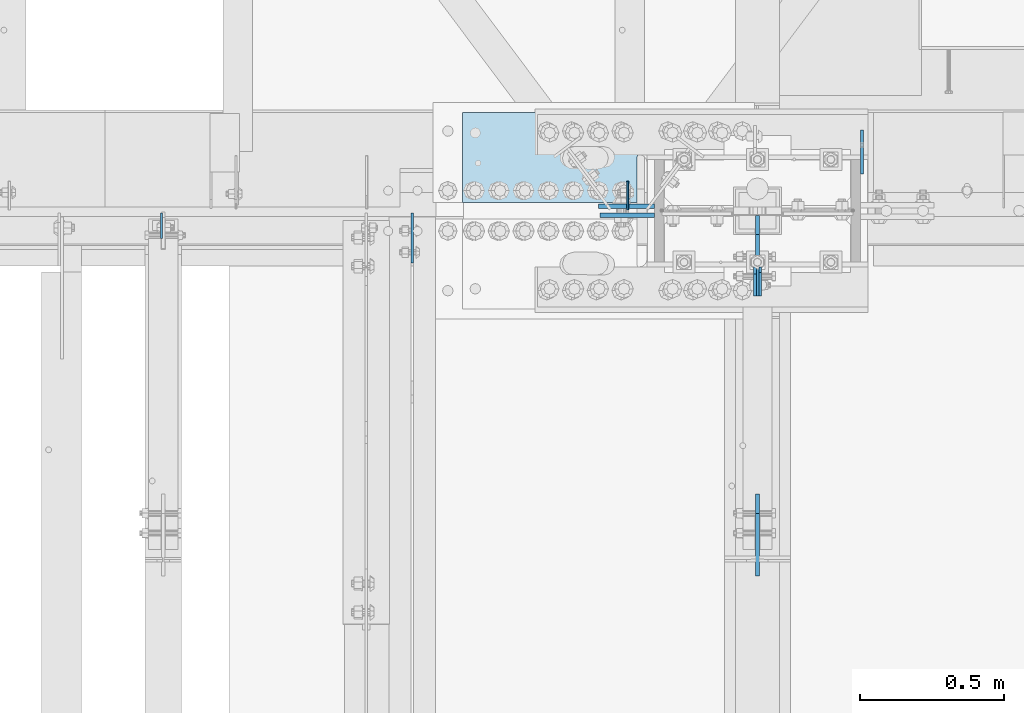
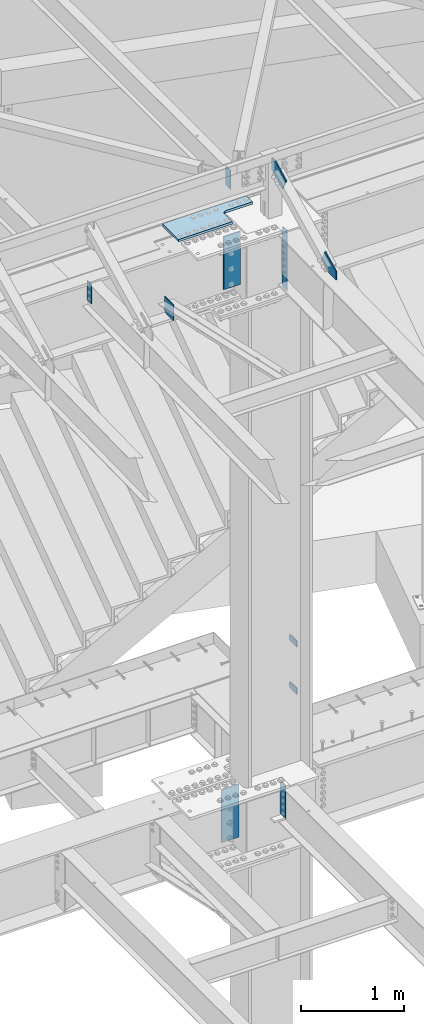
# One storey, part 1639 of 1763: 12 plates, 6 elements without a shape of their own.
"""IFC2X3 building model written with IfcOpenShell, lengths in millimetres."""

from ifc_helpers import new_model, si_unit, frame, origin_with_axes, place, context, subcontext, project, spatial, faceted_brep, material, type_object, element, aggregate, save


model = new_model("IFC2X3")

# Units and contexts
model_context = context("Model", 3, precision=1e-05, world=origin_with_axes())
body_context = subcontext(model_context, "Body", "Model", "MODEL_VIEW")
ifc_project = project(units=[si_unit("LENGTHUNIT", "METRE", prefix="MILLI"), si_unit("AREAUNIT", "SQUARE_METRE"), si_unit("VOLUMEUNIT", "CUBIC_METRE"), si_unit("MASSUNIT", "GRAM", prefix="KILO"), si_unit("TIMEUNIT", "SECOND"), si_unit("PLANEANGLEUNIT", "RADIAN"), si_unit("SOLIDANGLEUNIT", "STERADIAN"), si_unit("THERMODYNAMICTEMPERATUREUNIT", "DEGREE_CELSIUS"), si_unit("LUMINOUSINTENSITYUNIT", "LUMEN")], contexts=[model_context])

# Site, building, storey
site_placement = place(None, origin_with_axes())
site = spatial("IfcSite", under=ifc_project, at=site_placement, CompositionType="ELEMENT")
building_placement = place(site_placement, origin_with_axes())
building = spatial("IfcBuilding", under=site, at=building_placement, Name="Undefined", CompositionType="ELEMENT")
storey_placement = place(building_placement, origin_with_axes())
storey = spatial("IfcBuildingStorey", under=building, at=storey_placement, Name="Undefined", CompositionType="ELEMENT", Elevation=0.0)

# Assembly, plates
assembly_1_placement = place(storey_placement, origin_with_axes())
assembly_1 = element("IfcElementAssembly", 1, at=assembly_1_placement, inside=storey, Name="COLUMN", AssemblyPlace="NOTDEFINED", PredefinedType="RIGID_FRAME")
ifc_material_1 = material(Name="STEEL/A36")
plate_type_1 = type_object("IfcPlateType", PredefinedType="NOTDEFINED")
plate_1_placement = place(assembly_1_placement, frame((-34587.8872736983, 52247.8, 6489.69999847412), z_axis=(0.0, 0.0, -1.0), x_axis=(0.0, 1.0, 0.0)))
plate_1 = element("IfcPlate", 2, at=plate_1_placement, type_object=plate_type_1, material=ifc_material_1, Name="PLATE", context=body_context, shape_type="Brep", body=[
    faceted_brep([(0.0, -4.76249999999982, 0.0), (0.0, -4.76250000000073, 76.1999969482422), (0.0, 4.76250000000073, 76.1999969482422), (0.0, 4.76249999999982, 0.0), (114.299995422363, -4.76250000000073, 76.1999969482422), (114.299995422363, 4.76250000000073, 76.1999969482422), (126.073542436527, -4.76250000000073, 74.3352502937696), (126.073542436527, 4.76250000000073, 74.3352502937696), (136.694612637817, -4.76250000000073, 68.923544725345), (136.694612637817, 4.76250000000073, 68.923544725345), (145.123541673587, -4.76250000000073, 60.4946156895749), (145.123541673587, 4.76250000000073, 60.4946156895749), (150.535247242013, -4.76250000000073, 49.8735454882844), (150.535247242013, 4.76250000000073, 49.8735454882844), (152.399993896484, -4.76250000000073, 38.0999984741211), (152.399993896484, 4.76250000000073, 38.0999984741211), (150.535247242013, -4.76250000000073, 26.3264514599578), (150.535247242013, 4.76250000000073, 26.3264514599578), (145.123541673587, -4.76250000000073, 15.7053812586673), (145.123541673587, 4.76250000000073, 15.7053812586673), (136.694612637817, -4.76250000000073, 7.27645222289721), (136.694612637817, 4.76250000000073, 7.27645222289721), (126.073542436527, -4.76250000000073, 1.86474665447258), (126.073542436527, 4.76250000000073, 1.86474665447258), (114.299995422363, -4.76250000000073, 0.0), (114.299995422363, 4.76250000000073, 0.0)], [[[0, 1, 2, 3]], [[1, 4, 5, 2]], [[4, 6, 7, 5]], [[6, 8, 9, 7]], [[8, 10, 11, 9]], [[10, 12, 13, 11]], [[12, 14, 15, 13]], [[14, 16, 17, 15]], [[16, 18, 19, 17]], [[18, 20, 21, 19]], [[20, 22, 23, 21]], [[22, 24, 25, 23]], [[24, 0, 3, 25]], [[5, 7, 9, 11, 13, 15, 17, 19, 21, 23, 25, 3, 2]], [[24, 22, 20, 18, 16, 14, 12, 10, 8, 6, 4, 1, 0]]]),
])
plate_2_placement = place(assembly_1_placement, frame((-34587.8872736983, 52247.8, 5930.89999847412), z_axis=(0.0, 0.0, -1.0), x_axis=(0.0, 1.0, 0.0)))
plate_2 = element("IfcPlate", 3, at=plate_2_placement, type_object=plate_type_1, material=ifc_material_1, Name="PLATE", context=body_context, shape_type="Brep", body=[
    faceted_brep([(0.0, -4.76249999999982, 0.0), (0.0, -4.76250000000073, 76.1999969482422), (0.0, 4.76250000000073, 76.1999969482422), (0.0, 4.76249999999982, 0.0), (114.299995422363, -4.76250000000073, 76.1999969482422), (114.299995422363, 4.76250000000073, 76.1999969482422), (126.073542436527, -4.76250000000073, 74.3352502937696), (126.073542436527, 4.76250000000073, 74.3352502937696), (136.694612637817, -4.76250000000073, 68.923544725345), (136.694612637817, 4.76250000000073, 68.923544725345), (145.123541673587, -4.76250000000073, 60.4946156895749), (145.123541673587, 4.76250000000073, 60.4946156895749), (150.535247242013, -4.76250000000073, 49.8735454882844), (150.535247242013, 4.76250000000073, 49.8735454882844), (152.399993896484, -4.76250000000073, 38.0999984741211), (152.399993896484, 4.76250000000073, 38.0999984741211), (150.535247242013, -4.76250000000073, 26.3264514599578), (150.535247242013, 4.76250000000073, 26.3264514599578), (145.123541673587, -4.76250000000073, 15.7053812586673), (145.123541673587, 4.76250000000073, 15.7053812586673), (136.694612637817, -4.76250000000073, 7.27645222289721), (136.694612637817, 4.76250000000073, 7.27645222289721), (126.073542436527, -4.76250000000073, 1.86474665447258), (126.073542436527, 4.76250000000073, 1.86474665447258), (114.299995422363, -4.76250000000073, 0.0), (114.299995422363, 4.76250000000073, 0.0)], [[[0, 1, 2, 3]], [[1, 4, 5, 2]], [[4, 6, 7, 5]], [[6, 8, 9, 7]], [[8, 10, 11, 9]], [[10, 12, 13, 11]], [[12, 14, 15, 13]], [[14, 16, 17, 15]], [[16, 18, 19, 17]], [[18, 20, 21, 19]], [[20, 22, 23, 21]], [[22, 24, 25, 23]], [[24, 0, 3, 25]], [[5, 7, 9, 11, 13, 15, 17, 19, 21, 23, 25, 3, 2]], [[24, 22, 20, 18, 16, 14, 12, 10, 8, 6, 4, 1, 0]]]),
])
plate_type_2 = type_object("IfcPlateType", PredefinedType="NOTDEFINED")
plate_3_placement = place(assembly_1_placement, frame((-34940.3122734657, 51927.1249999994, 11716.7628223783), z_axis=(0.0, -1.0, 0.0), x_axis=(0.0, 0.0, -1.0)))
plate_3 = element("IfcPlate", 4, at=plate_3_placement, type_object=plate_type_2, material=ifc_material_1, Name="PLATE", context=body_context, shape_type="Brep", body=[
    faceted_brep([(0.0, -3.96899999999732, 19.0499992370605), (-1.18234311230481e-11, -3.96900000000096, 101.599998474121), (-1.18234311230481e-11, 3.96900000000096, 101.599998474121), (0.0, 3.96899999999732, 19.0499992370605), (717.549987792969, -3.96899999999732, 101.599998474121), (717.549987792969, 3.96899999999732, 101.599998474121), (717.549987792969, -3.96899999999732, 19.0499992370605), (717.549987792969, 3.96899999999732, 19.0499992370605), (698.499988555908, -3.96899999999732, 0.0), (698.499988555908, 3.96899999999732, 0.0), (19.0499992370605, -3.96899999999732, 0.0), (19.0499992370605, 3.96899999999732, 0.0)], [[[0, 1, 2, 3]], [[1, 4, 5, 2]], [[4, 6, 7, 5]], [[6, 8, 9, 7]], [[8, 10, 11, 9]], [[10, 0, 3, 11]], [[5, 7, 9, 11, 3, 2]], [[10, 8, 6, 4, 1, 0]]]),
])

# Assembly, plate
assembly_2_placement = place(storey_placement, origin_with_axes())
assembly_2 = element("IfcElementAssembly", 5, at=assembly_2_placement, inside=storey, Name="BEAM", AssemblyPlace="NOTDEFINED", PredefinedType="RIGID_FRAME")
plate_type_3 = type_object("IfcPlateType", PredefinedType="NOTDEFINED")
plate_4_placement = place(assembly_2_placement, frame((-34949.8372736984, 50858.8044431339, 11721.3897393301), z_axis=(0.0, -0.0206852279954837, 0.999786037781472), x_axis=(0.0, 0.999786037781472, 0.0206852279954825)))
plate_4 = element("IfcPlate", 6, at=plate_4_placement, type_object=plate_type_3, material=ifc_material_1, Name="PLATE", context=body_context, shape_type="Brep", body=[
    faceted_brep([(0.0, -6.34999999999491, 1.45519152283669e-11), (1.45519152283669e-11, -6.34999999999854, 101.599998474047), (1.45519152283669e-11, 6.34999999999854, 101.599998474047), (0.0, 6.34999999999491, -2.91038304567337e-11), (218.951583862981, -6.34999999999854, 205.463943481234), (218.951583862981, 6.34999999999854, 205.463943481234), (284.27273559654, -6.34999999999854, 67.7725906370797), (284.27273559654, 6.34999999999854, 67.7725906370797), (141.413955688891, -6.34999999999854, -4.72937244921923e-11), (141.413955688891, 6.34999999999854, -4.72937244921923e-11)], [[[0, 1, 2, 3]], [[1, 4, 5, 2]], [[4, 6, 7, 5]], [[6, 8, 9, 7]], [[8, 0, 3, 9]], [[5, 7, 9, 3, 2]], [[8, 6, 4, 1, 0]]]),
])
aggregate(assembly_2, [plate_4])

assembly_3_placement = place(storey_placement, origin_with_axes())
assembly_3 = element("IfcElementAssembly", 7, at=assembly_3_placement, inside=storey, Name="COLUMN", AssemblyPlace="NOTDEFINED", PredefinedType="RIGID_FRAME")
plate_type_4 = type_object("IfcPlateType", PredefinedType="NOTDEFINED")
plate_5_placement = place(assembly_3_placement, frame((-34949.8372736984, 52104.9250000007, 12416.9092242053), z_axis=(0.0, -1.0, 0.0), x_axis=(0.0, 0.0, -1.0)))
plate_5 = element("IfcPlate", 8, at=plate_5_placement, type_object=plate_type_4, material=ifc_material_1, Name="PLATE", context=body_context, shape_type="Brep", body=[
    faceted_brep([(0.0, -6.34999999999491, 1.45519152283669e-11), (0.0, -6.34999999999854, 66.6750030517578), (0.0, 6.34999999999854, 66.6750030517578), (0.0, 6.34999999999491, -2.91038304567337e-11), (109.25341796875, -6.34999999999854, 278.831817626953), (109.25341796875, 6.34999999999854, 278.831817626953), (245.564117431641, -6.34999999999854, 210.676483154297), (245.564117431641, 6.34999999999854, 210.676483154297), (140.225875854492, -6.34999999999854, 0.0), (140.225875854492, 6.34999999999854, 0.0)], [[[0, 1, 2, 3]], [[1, 4, 5, 2]], [[4, 6, 7, 5]], [[6, 8, 9, 7]], [[8, 0, 3, 9]], [[5, 7, 9, 3, 2]], [[8, 6, 4, 1, 0]]]),
])
aggregate(assembly_3, [plate_5])

# Plate
ifc_material_2 = material(Name="STEEL/A572-GR.50")
plate_type_5 = type_object("IfcPlateType", PredefinedType="NOTDEFINED")
plate_6_placement = place(assembly_1_placement, frame((-34958.5685236983, 51927.125, 5165.725), z_axis=(0.0, -1.0, 0.0), x_axis=(0.0, 0.0, -1.0)))
plate_6 = element("IfcPlate", 9, at=plate_6_placement, type_object=plate_type_5, material=ifc_material_2, Name="PLATE", context=body_context, shape_type="Brep", body=[
    faceted_brep([(25.3999996185303, -4.76250000000073, 0.0), (0.0, -4.76250000000073, 25.3999996185303), (0.0, 4.76250000000073, 25.3999996185303), (25.3999996185303, 4.76250000000073, 0.0), (1.45519152283669e-11, -4.76250000000448, 101.60001373291), (390.524993896484, -4.76249999999709, 101.599998474121), (390.524993896484, 4.76249999999709, 101.599998474121), (0.0, 4.76250000000243, 101.60001373291), (390.524993896484, -4.76249999999709, 0.0), (390.524993896484, 4.76249999999709, 0.0)], [[[0, 1, 2, 3]], [[4, 5, 6, 7]], [[5, 8, 9, 6]], [[9, 8, 0, 3]], [[7, 6, 9, 3, 2]], [[4, 7, 2, 1]], [[8, 5, 4, 1, 0]]]),
])

# Assembly, plate
assembly_4_placement = place(storey_placement, origin_with_axes())
assembly_4 = element("IfcElementAssembly", 10, at=assembly_4_placement, inside=storey, Name="BEAM", AssemblyPlace="NOTDEFINED", PredefinedType="RIGID_FRAME")
plate_type_6 = type_object("IfcPlateType", PredefinedType="NOTDEFINED")
plate_7_placement = place(assembly_4_placement, frame((-35398.7396174484, 52123.9749997282, 12407.9), z_axis=(0.0, 1.0, 0.0), x_axis=(0.0, 0.0, -1.0)))
plate_7 = element("IfcPlate", 11, at=plate_7_placement, type_object=plate_type_6, material=ifc_material_1, Name="PLATE", context=body_context, shape_type="Brep", body=[
    faceted_brep([(1.81898940354586e-12, -3.17500000000291, 0.0), (-2.52839527092874e-10, -3.17500000000001, 98.4250000002357), (4.17785486206412e-08, 3.17500000000001, 98.425000000243), (-1.81898940354586e-12, 3.17499999997381, 0.0), (228.600006103516, -3.17499999999927, 98.4250030517578), (228.600006103516, 3.17499999999927, 98.4250030517578), (228.600006103516, -3.17500000001019, -7.27595761418343e-12), (228.600006103516, 3.17499999999563, -7.27595761418343e-12)], [[[0, 1, 2, 3]], [[1, 4, 5, 2]], [[4, 6, 7, 5]], [[6, 0, 3, 7]], [[5, 7, 3, 2]], [[6, 4, 1, 0]]]),
])
aggregate(assembly_4, [plate_7])

# Plate
ifc_material_3 = material(Name="STEEL/A572-50")
plate_type_7 = type_object("IfcPlateType", PredefinedType="NOTDEFINED")
plate_8_placement = place(assembly_1_placement, frame((-35494.3497736984, 52104.9250002128, 11045.8249917654), z_axis=(1.0, 0.0, 0.0), x_axis=(0.0, 0.0, 1.0)))
plate_8 = element("IfcPlate", 12, at=plate_8_placement, type_object=plate_type_7, material=ifc_material_3, Name="SHEAR TAB", context=body_context, shape_type="Brep", body=[
    faceted_brep([(-7.27595761418343e-12, -7.9375, 0.0), (0.0, -7.9375, 187.324996948242), (0.0, 7.9375, 187.324996948242), (-7.27595761418343e-12, 7.9375, 0.0), (625.474975585938, -7.9375, 187.324996948242), (625.474975585938, 7.9375, 187.324996948242), (625.474975585938, -7.9375, 0.0), (625.474975585938, 7.9375, 0.0)], [[[0, 1, 2, 3]], [[1, 4, 5, 2]], [[4, 6, 7, 5]], [[6, 0, 3, 7]], [[5, 7, 3, 2]], [[6, 4, 1, 0]]]),
])

# Assembly, plate
assembly_5_placement = place(storey_placement, origin_with_axes())
assembly_5 = element("IfcElementAssembly", 13, at=assembly_5_placement, inside=storey, Name="TOP PLATE", AssemblyPlace="NOTDEFINED", PredefinedType="RIGID_FRAME")
plate_type_8 = type_object("IfcPlateType", PredefinedType="NOTDEFINED")
plate_9_placement = place(assembly_5_placement, frame((-35970.5997736984, 52149.3750002128, 11761.7874917654), z_axis=(0.0, 1.0, 0.0), x_axis=(1.0, 0.0, 0.0)))
plate_9 = element("IfcPlate", 14, at=plate_9_placement, type_object=plate_type_8, material=ifc_material_3, Name="TOP PLATE", context=body_context, shape_type="Brep", body=[
    faceted_brep([(0.0, -14.2875000000058, 0.0), (0.0, -14.2875000000004, 311.149993896484), (0.0, 14.2875000000004, 311.149993896484), (0.0, 14.2875000000058, 0.0), (939.799987792969, -14.2875000000004, 311.149993896484), (939.799987792969, 14.2875000000004, 311.149993896484), (939.799987792969, -14.2875000000004, 193.675003051758), (939.799987792969, 14.2875000000004, 193.675003051758), (644.525001525879, -14.2875000000004, 193.675003051758), (644.525001525879, 14.2875000000004, 193.675003051758), (628.729742271084, -14.2875000000004, 190.533130640011), (628.729742271084, 14.2875000000004, 190.533130640011), (615.339168053448, -14.2875000000004, 181.58583499831), (615.339168053448, 14.2875000000004, 181.58583499831), (606.391872411747, -14.2875000000004, 168.195260780674), (606.391872411747, 14.2875000000004, 168.195260780674), (603.25, -14.2875000000004, 152.400001525879), (603.25, 14.2875000000004, 152.400001525879), (603.25, -14.2875000000004, 0.0), (603.25, 14.2875000000004, 0.0)], [[[0, 1, 2, 3]], [[1, 4, 5, 2]], [[4, 6, 7, 5]], [[6, 8, 9, 7]], [[8, 10, 11, 9]], [[10, 12, 13, 11]], [[12, 14, 15, 13]], [[14, 16, 17, 15]], [[16, 18, 19, 17]], [[18, 0, 3, 19]], [[5, 7, 9, 11, 13, 15, 17, 19, 3, 2]], [[18, 16, 14, 12, 10, 8, 6, 4, 1, 0]]]),
])
aggregate(assembly_5, [plate_9])

# Plate
plate_type_9 = type_object("IfcPlateType", PredefinedType="NOTDEFINED")
plate_10_placement = place(assembly_1_placement, frame((-35500.6997736984, 52136.675, 4494.2125), z_axis=(1.0, 0.0, 0.0), x_axis=(0.0, 0.0, 1.0)))
plate_10 = element("IfcPlate", 15, at=plate_10_placement, type_object=plate_type_9, material=ifc_material_3, Name="SHEAR TAB", context=body_context, shape_type="Brep", body=[
    faceted_brep([(-7.27595761418343e-12, -7.9375, 0.0), (0.0, -7.9375, 193.675003051758), (0.0, 7.9375, 193.675003051758), (-7.27595761418343e-12, 7.9375, 0.0), (625.474975585938, -7.9375, 193.675003051758), (625.474975585938, 7.9375, 193.675003051758), (625.474975585938, -7.9375, 0.0), (625.474975585938, 7.9375, 0.0)], [[[0, 1, 2, 3]], [[1, 4, 5, 2]], [[4, 6, 7, 5]], [[6, 0, 3, 7]], [[5, 7, 3, 2]], [[6, 4, 1, 0]]]),
])

aggregate(assembly_1, [plate_1, plate_2, plate_3, plate_8, plate_6, plate_10])

# Assembly, plates
assembly_6_placement = place(storey_placement, origin_with_axes())
assembly_6 = element("IfcElementAssembly", 16, at=assembly_6_placement, inside=storey, Name="BEAM", AssemblyPlace="NOTDEFINED", PredefinedType="RIGID_FRAME")
plate_type_10 = type_object("IfcPlateType", PredefinedType="NOTDEFINED")
plate_11_placement = place(assembly_6_placement, frame((-36144.6956070317, 52112.8625002128, 11004.5499917654), z_axis=(0.0, 0.0, 1.0), x_axis=(0.0, -1.0, 0.0)))
plate_11 = element("IfcPlate", 17, at=plate_11_placement, type_object=plate_type_10, material=ifc_material_1, Name="PLATE", context=body_context, shape_type="Brep", body=[
    faceted_brep([(0.0, -4.76250000000073, 31.75), (0.0, -4.76249999999709, 185.166687011719), (0.0, 4.76249999999709, 185.166687011719), (0.0, 4.76250000000073, 31.75), (173.381103515625, -4.76249999999709, 185.166687011719), (173.381103515625, 4.76249999999709, 185.166687011719), (173.381103515625, -4.76249999999709, 7.27595761418343e-12), (173.381103515625, 4.76249999999709, 7.27595761418343e-12), (31.75, -4.76250000000073, 0.0), (31.75, 4.76250000000073, 0.0)], [[[0, 1, 2, 3]], [[1, 4, 5, 2]], [[4, 6, 7, 5]], [[6, 8, 9, 7]], [[8, 0, 3, 9]], [[5, 7, 9, 3, 2]], [[8, 6, 4, 1, 0]]]),
])
plate_type_11 = type_object("IfcPlateType", PredefinedType="NOTDEFINED")
plate_12_placement = place(assembly_6_placement, frame((-37012.3822886427, 52112.8625002128, 11684.3836745228), z_axis=(0.0, -1.0, 0.0), x_axis=(0.0, 0.0, -1.0)))
plate_12 = element("IfcPlate", 18, at=plate_12_placement, type_object=plate_type_11, material=ifc_material_1, Name="PLATE", context=body_context, shape_type="Brep", body=[
    faceted_brep([(1.81898940354586e-12, -3.17500000000291, 0.0), (0.0, -3.17500000000291, 87.3125), (0.0, 3.17500000000291, 87.3125), (-1.81898940354586e-12, 3.17499999997381, 0.0), (228.600006103516, -3.17500000000291, 87.3125), (228.600006103516, 3.17500000000291, 87.3125), (228.600006103516, -3.17500000001019, -7.27595761418343e-12), (228.600006103516, 3.17499999999563, -7.27595761418343e-12)], [[[0, 1, 2, 3]], [[1, 4, 5, 2]], [[4, 6, 7, 5]], [[6, 0, 3, 7]], [[5, 7, 3, 2]], [[6, 4, 1, 0]]]),
])
aggregate(assembly_6, [plate_11, plate_12])

save(model, "model.ifc")
